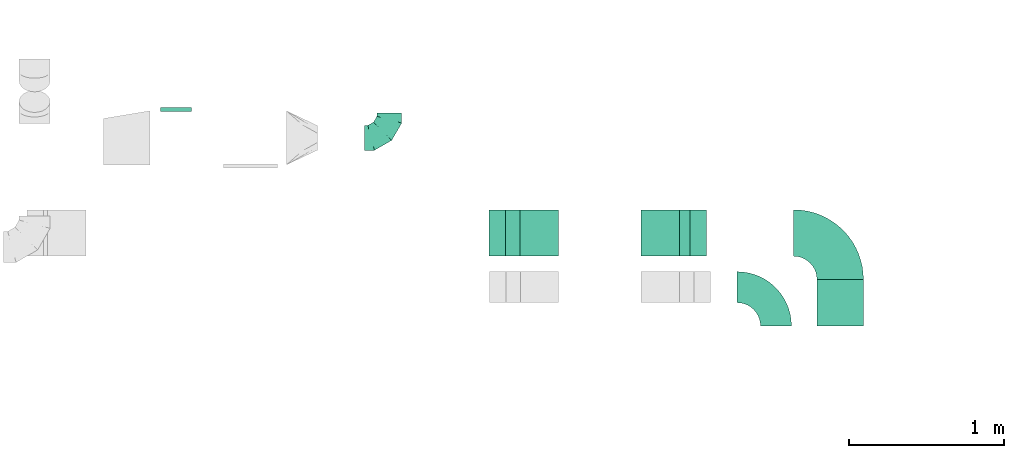
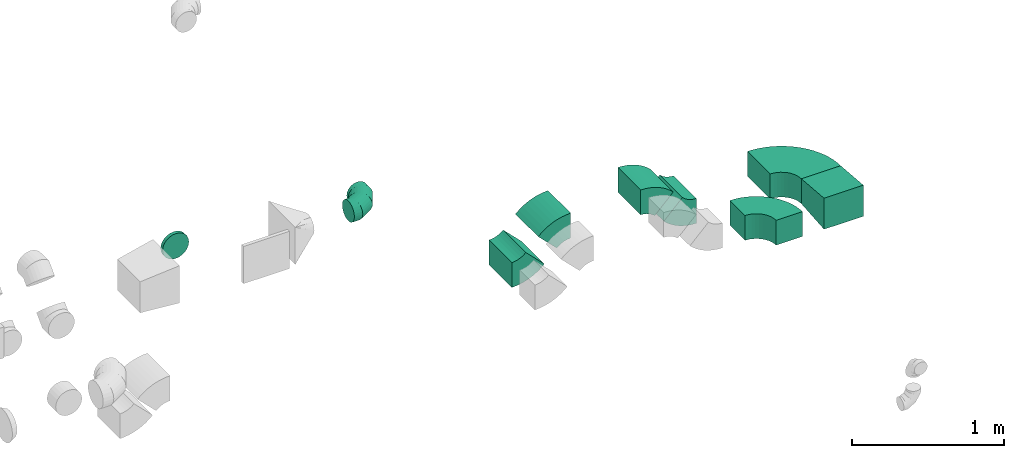
# One storey, part 31 of 44: 9 flow fittings.
"""IFC2X3 building model written with IfcOpenShell, lengths in millimetres."""

import ifcopenshell
import ifcopenshell.guid

model = None  # the IFC model being written
_history = None  # IfcOwnerHistory: only IFC2X3 demands one
_inside = {}  # id of a spatial element -> (the spatial element, [elements in it])
_under = {}  # id of a project, library or spatial element -> (it, [spatial elements below it])
_declared = {}  # id of a project -> (the project, [libraries it declares])
_typed = {}  # id of a type object -> (the type object, [elements of that type])
_made_of = {}  # id of a material, layer set ... -> (it, [elements and type objects made of it])


def new_model(schema):
    """Start an empty IFC model of exactly this schema.

    Asked for "IFC4X3", IfcOpenShell would pick the latest addendum, in which some entities
    have other attributes; the version numbers below select the first issue.
    IFC2X3 requires an IfcOwnerHistory on every rooted entity: one is made here for all.
    """
    global model, _history
    if schema == "IFC4X3":
        model = ifcopenshell.file(schema_version=(4, 3, 0, 0))
    else:
        model = ifcopenshell.file(schema=schema)
    _inside.clear()
    _under.clear()
    _declared.clear()
    _typed.clear()
    _made_of.clear()
    _history = None
    if model.schema == "IFC2X3":
        org = make("IfcOrganization", Name="unknown")
        user = make(
            "IfcPersonAndOrganization",
            ThePerson=make("IfcPerson", FamilyName="unknown"),
            TheOrganization=org,
        )
        app = make(
            "IfcApplication",
            ApplicationDeveloper=org,
            Version="unknown",
            ApplicationFullName="unknown",
            ApplicationIdentifier="unknown",
        )
        _history = make(
            "IfcOwnerHistory",
            OwningUser=user,
            OwningApplication=app,
            ChangeAction="ADDED",
            CreationDate=0,
        )
    return model


def make(cls, **values):
    """One entity of the class cls with the attributes given. An attribute that is None is left unset."""
    return model.create_entity(
        cls, **{name: value for name, value in values.items() if value is not None}
    )


def entity(cls, *values):
    """Any entity or typed value of the class cls, its attributes in the order of the schema. None: left unset."""
    e = model.create_entity(cls)
    for i, value in enumerate(values):
        if value is not None:
            e[i] = value
    return e


def rooted(cls, **values):
    """An entity with a GlobalId (a new one), such as an element, a storey or a relation."""
    return make(cls, GlobalId=ifcopenshell.guid.new(), OwnerHistory=_history, **values)


def si_unit(unit_type, name, prefix=None):
    """IfcSIUnit, for example si_unit("LENGTHUNIT", "METRE", prefix="MILLI")."""
    return make("IfcSIUnit", UnitType=unit_type, Prefix=prefix, Name=name)


def converted_unit(unit_type, name, factor, base, dimensions=None, offset=None):
    """IfcConversionBasedUnit, such as the inch: factor (a typed value) times the base unit."""
    return make(
        "IfcConversionBasedUnit"
        if offset is None
        else "IfcConversionBasedUnitWithOffset",
        ConversionOffset=offset,
        Dimensions=None
        if dimensions is None
        else entity("IfcDimensionalExponents", *dimensions),
        UnitType=unit_type,
        Name=name,
        ConversionFactor=make(
            "IfcMeasureWithUnit", ValueComponent=factor, UnitComponent=base
        ),
    )


def derived_unit(unit_type, elements):
    """IfcDerivedUnit: a product of units, each with its exponent."""
    return make(
        "IfcDerivedUnit",
        Elements=[
            make("IfcDerivedUnitElement", Unit=unit, Exponent=power)
            for unit, power in elements
        ],
        UnitType=unit_type,
    )


def assignment(units):
    """IfcUnitAssignment: the units of a project."""
    return None if units is None else make("IfcUnitAssignment", Units=units)


def point(xyz):
    """IfcCartesianPoint."""
    return None if xyz is None else make("IfcCartesianPoint", Coordinates=xyz)


def direction(xyz):
    """IfcDirection."""
    return None if xyz is None else make("IfcDirection", DirectionRatios=xyz)


def frame(location, z_axis=None, x_axis=None):
    """IfcAxis2Placement3D, a coordinate frame: its origin and axes. An axis left out is left unset."""
    return make(
        "IfcAxis2Placement3D",
        Location=point(location),
        Axis=direction(z_axis),
        RefDirection=direction(x_axis),
    )


def frame_2d(location, x_axis=None):
    """IfcAxis2Placement2D, a coordinate frame in the plane: its origin and x axis."""
    return make(
        "IfcAxis2Placement2D", Location=point(location), RefDirection=direction(x_axis)
    )


def origin():
    """The frame at (0, 0, 0) with its axes left unset."""
    return frame((0.0, 0.0, 0.0))


def place(relative_to, where):
    """IfcLocalPlacement: puts the frame where relative to a parent placement (None: the world)."""
    return make(
        "IfcLocalPlacement", PlacementRelTo=relative_to, RelativePlacement=where
    )


def context(
    kind, dimensions, precision=None, world=None, true_north=None, identifier=None
):
    """IfcGeometricRepresentationContext, for example the 3D "Model" context."""
    return make(
        "IfcGeometricRepresentationContext",
        ContextIdentifier=identifier,
        ContextType=kind,
        CoordinateSpaceDimension=dimensions,
        Precision=precision,
        WorldCoordinateSystem=world,
        TrueNorth=true_north,
    )


def subcontext(parent, identifier, kind, view, scale=None):
    """IfcGeometricRepresentationSubContext, for example "Body" below "Model"."""
    return make(
        "IfcGeometricRepresentationSubContext",
        ContextIdentifier=identifier,
        ContextType=kind,
        ParentContext=parent,
        TargetScale=scale,
        TargetView=view,
    )


def project(units=None, contexts=None):
    """IfcProject with its units and contexts."""
    return rooted(
        "IfcProject",
        Name="project",
        RepresentationContexts=contexts,
        UnitsInContext=assignment(units),
    )


def spatial(cls, under=None, at=None, **own):
    """A site, building, storey or space (cls), placed at a placement, below another one or the project."""
    s = rooted(cls, ObjectPlacement=at, **own)
    if under is not None:
        _under.setdefault(under.id(), (under, []))[1].append(s)
    return s


def polyline(points):
    """IfcPolyline through the points."""
    return make("IfcPolyline", Points=[point(p) for p in points])


def circle_curve(where, radius):
    """IfcCircle in the frame where."""
    return make("IfcCircle", Position=where, Radius=radius)


def parameter(value):
    """IfcParameterValue: where a trimmed curve begins or ends, as a parameter of its basis curve."""
    return model.create_entity("IfcParameterValue", value)


def trimmed(basis, trim1, trim2, sense, master):
    """IfcTrimmedCurve: the piece of a basis curve between two trims."""
    return make(
        "IfcTrimmedCurve",
        BasisCurve=basis,
        Trim1=trim1,
        Trim2=trim2,
        SenseAgreement=sense,
        MasterRepresentation=master,
    )


def segment(curve, same_sense, transition):
    """IfcCompositeCurveSegment."""
    return make(
        "IfcCompositeCurveSegment",
        Transition=transition,
        SameSense=same_sense,
        ParentCurve=curve,
    )


def composite_curve(segments, self_intersect=None):
    """IfcCompositeCurve: segments joined end to end."""
    return make("IfcCompositeCurve", Segments=segments, SelfIntersect=self_intersect)


def outline(outer, holes=None, kind="AREA"):
    """IfcArbitraryClosedProfileDef: a profile drawn as a closed curve; with holes, ...WithVoids."""
    if holes is None:
        return make("IfcArbitraryClosedProfileDef", ProfileType=kind, OuterCurve=outer)
    return make(
        "IfcArbitraryProfileDefWithVoids",
        ProfileType=kind,
        OuterCurve=outer,
        InnerCurves=holes,
    )


def extrude(swept, where, along, depth):
    """IfcExtrudedAreaSolid: the profile swept, set in the frame where, extruded along a direction by depth."""
    return make(
        "IfcExtrudedAreaSolid",
        SweptArea=swept,
        Position=where,
        ExtrudedDirection=direction(along),
        Depth=depth,
    )


def faces_of(points, faces, orient=None, outer=None):
    """IfcFace entities. A face is a list of loops; a loop is a list of indices into points, from 0.

    orient and outer hold one flag for each loop. By default every Orientation is true, the
    first loop of a face is its IfcFaceOuterBound and the others are IfcFaceBound.
    """
    made = []
    for i, loops in enumerate(faces):
        bounds = []
        for j, loop in enumerate(loops):
            is_outer = j == 0 if outer is None else outer[i][j]
            bounds.append(
                make(
                    "IfcFaceOuterBound" if is_outer else "IfcFaceBound",
                    Bound=make("IfcPolyLoop", Polygon=[points[k] for k in loop]),
                    Orientation=True if orient is None else orient[i][j],
                )
            )
        made.append(make("IfcFace", Bounds=bounds))
    return made


def faceted_brep(points, faces, orient=None, outer=None, voids=None):
    """IfcFacetedBrep: a solid bounded by flat faces; with voids (closed shells), ...WithVoids."""
    shared = [point(p) for p in points]
    hull = make("IfcClosedShell", CfsFaces=faces_of(shared, faces, orient, outer))
    if voids is None:
        return make("IfcFacetedBrep", Outer=hull)
    return make(
        "IfcFacetedBrepWithVoids",
        Outer=hull,
        Voids=[
            make(cls, CfsFaces=faces_of(shared, fs, o, b)) for cls, fs, o, b in voids
        ],
    )


def shape(context_of_items, identifier, shape_type, items):
    """IfcShapeRepresentation: the items that make up one representation, for example the "Body"."""
    return make(
        "IfcShapeRepresentation",
        ContextOfItems=context_of_items,
        RepresentationIdentifier=identifier,
        RepresentationType=shape_type,
        Items=items,
    )


def source(mapping_origin, context_of_items, identifier, shape_type, items):
    """IfcRepresentationMap: a shape defined once, which mapped items show again and again."""
    return make(
        "IfcRepresentationMap",
        MappingOrigin=mapping_origin,
        MappedRepresentation=shape(context_of_items, identifier, shape_type, items),
    )


def transform(
    local_origin,
    x_axis=None,
    y_axis=None,
    z_axis=None,
    scale=None,
    scale2=None,
    scale3=None,
    uniform=True,
):
    """IfcCartesianTransformationOperator3D, or its non-uniform kind. x_axis, y_axis, z_axis: its Axis1, 2, 3."""
    if uniform:
        return make(
            "IfcCartesianTransformationOperator3D",
            Axis1=direction(x_axis),
            Axis2=direction(y_axis),
            LocalOrigin=point(local_origin),
            Scale=scale,
            Axis3=direction(z_axis),
        )
    return make(
        "IfcCartesianTransformationOperator3DnonUniform",
        Axis1=direction(x_axis),
        Axis2=direction(y_axis),
        LocalOrigin=point(local_origin),
        Scale=scale,
        Axis3=direction(z_axis),
        Scale2=scale2,
        Scale3=scale3,
    )


def mapped(mapping_source, mapping_target):
    """IfcMappedItem: shows the shape of a source again, moved by a transform."""
    return make(
        "IfcMappedItem", MappingSource=mapping_source, MappingTarget=mapping_target
    )


def material(Name=None, Category=None):
    """IfcMaterial."""
    return make("IfcMaterial", Name=Name, Category=Category)


def made_of(thing, what):
    """Note that an element or type object is made of a material, layer set ...; save() writes the relation."""
    if what is not None:
        _made_of.setdefault(what.id(), (what, []))[1].append(thing)
    return thing


def type_object(cls, material=None, **own):
    """A type object (cls), such as IfcWallType, which elements share."""
    return made_of(rooted(cls, **own), material)


def type_shapes(of_type, sources):
    """Give a type object the sources (RepresentationMaps) that its elements show as mapped items."""
    of_type.RepresentationMaps = sources


def element(
    cls,
    number,
    at=None,
    inside=None,
    cuts=None,
    type_object=None,
    material=None,
    context=None,
    identifier="Body",
    shape_type=None,
    held_by="IfcProductDefinitionShape",
    body=None,
    shapes=None,
    **own,
):
    """One element of the class cls, such as IfcWall. Its Tag is "e" and its number.

    at: its placement. inside: the storey or other place that contains it. cuts: it is an
    opening in that element (IfcRelVoidsElement). A single representation is given by context,
    identifier, shape_type and body (its items); several are given by shapes. held_by: the class
    of the entity that holds the representations. save() writes the other relations.
    """
    e = rooted(cls, Tag="e%d" % number, ObjectPlacement=at, **own)
    if body is not None:
        shapes = [shape(context, identifier, shape_type, body)]
    if shapes is not None:
        e.Representation = make(held_by, Representations=shapes)
    if inside is not None:
        _inside.setdefault(inside.id(), (inside, []))[1].append(e)
    if cuts is not None:
        rooted(
            "IfcRelVoidsElement", RelatingBuildingElement=cuts, RelatedOpeningElement=e
        )
    if type_object is not None:
        _typed.setdefault(type_object.id(), (type_object, []))[1].append(e)
    return made_of(e, material)


def aggregate(whole, parts):
    """IfcRelAggregates: a whole, such as a stair, and the parts it consists of."""
    return rooted("IfcRelAggregates", RelatingObject=whole, RelatedObjects=parts)


def save(model, path):
    """Write the relations noted so far, then the file.

    IfcRelAggregates (storeys below a building ...), IfcRelContainedInSpatialStructure (elements
    in a storey), IfcRelDefinesByType, IfcRelAssociatesMaterial and IfcRelDeclares: one each for
    every whole, place, type object, material and project.
    """
    for whole, parts in _under.values():
        aggregate(whole, parts)
    for where, things in _inside.values():
        rooted(
            "IfcRelContainedInSpatialStructure",
            RelatedElements=things,
            RelatingStructure=where,
        )
    for kind, things in _typed.values():
        rooted("IfcRelDefinesByType", RelatedObjects=things, RelatingType=kind)
    for what, things in _made_of.values():
        rooted("IfcRelAssociatesMaterial", RelatedObjects=things, RelatingMaterial=what)
    for by, libraries in _declared.values():
        rooted("IfcRelDeclares", RelatingContext=by, RelatedDefinitions=libraries)
    model.write(path)


model = new_model("IFC2X3")

# Units and contexts
model_context = context("Model", 3, precision=0.01, world=origin(), true_north=direction((6.12303176911189e-17, 1.0)))
body_context = subcontext(model_context, "Body", "Model", "MODEL_VIEW")
ifc_project = project(units=[si_unit("LENGTHUNIT", "METRE", prefix="MILLI"), si_unit("AREAUNIT", "SQUARE_METRE"), si_unit("VOLUMEUNIT", "CUBIC_METRE"), converted_unit("PLANEANGLEUNIT", "DEGREE", entity("IfcRatioMeasure", 0.0174532925199433), si_unit("PLANEANGLEUNIT", "RADIAN"), dimensions=[0, 0, 0, 0, 0, 0, 0]), si_unit("MASSUNIT", "GRAM", prefix="KILO"), derived_unit("MASSDENSITYUNIT", [(si_unit("MASSUNIT", "GRAM", prefix="KILO"), 1), (si_unit("LENGTHUNIT", "METRE"), -3)]), derived_unit("MOMENTOFINERTIAUNIT", [(si_unit("LENGTHUNIT", "METRE"), 4)]), si_unit("TIMEUNIT", "SECOND"), si_unit("FREQUENCYUNIT", "HERTZ"), si_unit("THERMODYNAMICTEMPERATUREUNIT", "DEGREE_CELSIUS"), derived_unit("THERMALTRANSMITTANCEUNIT", [(si_unit("MASSUNIT", "GRAM", prefix="KILO"), 1), (si_unit("THERMODYNAMICTEMPERATUREUNIT", "KELVIN"), -1), (si_unit("TIMEUNIT", "SECOND"), -3)]), derived_unit("VOLUMETRICFLOWRATEUNIT", [(si_unit("LENGTHUNIT", "METRE"), 3), (si_unit("TIMEUNIT", "SECOND"), -1)]), derived_unit("MASSFLOWRATEUNIT", [(si_unit("MASSUNIT", "GRAM", prefix="KILO"), 1), (si_unit("TIMEUNIT", "SECOND"), -1)]), derived_unit("ROTATIONALFREQUENCYUNIT", [(si_unit("TIMEUNIT", "SECOND"), -1)]), si_unit("ELECTRICCURRENTUNIT", "AMPERE"), si_unit("ELECTRICVOLTAGEUNIT", "VOLT"), si_unit("POWERUNIT", "WATT"), si_unit("FORCEUNIT", "NEWTON", prefix="KILO"), si_unit("ILLUMINANCEUNIT", "LUX"), si_unit("LUMINOUSFLUXUNIT", "LUMEN"), si_unit("LUMINOUSINTENSITYUNIT", "CANDELA"), derived_unit("USERDEFINED", [(si_unit("MASSUNIT", "GRAM", prefix="KILO"), -1), (si_unit("LENGTHUNIT", "METRE"), -2), (si_unit("TIMEUNIT", "SECOND"), 3), (si_unit("LUMINOUSFLUXUNIT", "LUMEN"), 1)]), derived_unit("LINEARVELOCITYUNIT", [(si_unit("LENGTHUNIT", "METRE"), 1), (si_unit("TIMEUNIT", "SECOND"), -1)]), si_unit("PRESSUREUNIT", "PASCAL"), derived_unit("USERDEFINED", [(si_unit("LENGTHUNIT", "METRE"), -2), (si_unit("MASSUNIT", "GRAM", prefix="KILO"), 1), (si_unit("TIMEUNIT", "SECOND"), -2)]), derived_unit("LINEARFORCEUNIT", [(si_unit("MASSUNIT", "GRAM", prefix="KILO"), 1), (si_unit("LENGTHUNIT", "METRE"), 1), (si_unit("TIMEUNIT", "SECOND"), -2), (si_unit("LENGTHUNIT", "METRE"), -1)]), derived_unit("PLANARFORCEUNIT", [(si_unit("MASSUNIT", "GRAM", prefix="KILO"), 1), (si_unit("LENGTHUNIT", "METRE"), 1), (si_unit("TIMEUNIT", "SECOND"), -2), (si_unit("LENGTHUNIT", "METRE"), -2)])], contexts=[model_context])

# Site, building, storey
site_placement = place(None, origin())
site = spatial("IfcSite", under=ifc_project, at=site_placement, CompositionType="ELEMENT")
building_placement = place(site_placement, origin())
building = spatial("IfcBuilding", under=site, at=building_placement, CompositionType="ELEMENT")
storey_placement = place(building_placement, frame((0.0, 0.0, 15900.0)))
storey = spatial("IfcBuildingStorey", under=building, at=storey_placement, CompositionType="ELEMENT", Elevation=15900.0)

# Flow fittings
ifc_material = material()
duct_fitting_type_1 = type_object("IfcDuctFittingType", PredefinedType="NOTDEFINED", material=ifc_material)
shared_shape_1 = source(origin(), body_context, "Body", "SweptSolid", [
    extrude(outline(polyline([(-159.86, -112.11), (141.18, -112.11), (157.79, 87.2), (-139.1, 137.03), (-159.86, -112.11)])), frame((150.0, -150.0, 0.0), z_axis=(0.0, 1.0, 0.0), x_axis=(0.996545758244872, 0.0, -0.0830454798538357)), (0.0, 0.0, 1.0), 300.0),
])
type_shapes(duct_fitting_type_1, [shared_shape_1])
flow_fitting_1_placement = place(storey_placement, frame((62044.65, 13925.32, 2975.0), z_axis=(0.0, 0.0, 1.0), x_axis=(0.0, 1.0, 0.0)))
element("IfcFlowFitting", 1, at=flow_fitting_1_placement, inside=storey, type_object=duct_fitting_type_1, material=ifc_material, context=body_context, shape_type="MappedRepresentation", body=[
    mapped(shared_shape_1, transform((0.0, 0.0, 0.0), scale=1.0)),
])
duct_fitting_type_2 = type_object("IfcDuctFittingType", PredefinedType="NOTDEFINED", material=ifc_material)
shared_shape_2 = source(origin(), body_context, "Body", "Brep", [
    faceted_brep([(-160.0, 0.0, -80.0), (-160.0, -20.71, -77.27), (-160.0, -40.0, -69.28), (-160.0, -56.57, -56.57), (-160.0, -69.28, -40.0), (-160.0, -77.27, -20.71), (-160.0, -80.0, 0.0), (-160.0, -77.27, 20.71), (-160.0, -69.28, 40.0), (-160.0, -56.57, 56.57), (-160.0, -40.0, 69.28), (-160.0, -20.71, 77.27), (-160.0, 0.0, 80.0), (-160.0, 20.71, 77.27), (-160.0, 40.0, 69.28), (-160.0, 56.57, 56.57), (-160.0, 69.28, 40.0), (-160.0, 77.27, 20.71), (-160.0, 80.0, 0.0), (-160.0, 77.27, -20.71), (-160.0, 69.28, -40.0), (-160.0, 56.57, -56.57), (-160.0, 40.0, -69.28), (-160.0, 20.71, -77.27), (-122.68, 20.71, 77.27), (-127.85, 40.0, 69.28), (-117.13, 0.0, 80.0), (-132.29, 56.57, 56.57), (-137.83, 77.27, 20.71), (-138.56, 80.0, 0.0), (-135.69, 69.28, 40.0), (-135.69, 69.28, -40.0), (-132.29, 56.57, -56.57), (-137.83, 77.27, -20.71), (-122.68, 20.71, -77.27), (-117.13, 0.0, -80.0), (-127.85, 40.0, -69.28), (-111.58, -20.71, -77.27), (-106.41, -40.0, -69.28), (-101.97, -56.57, -56.57), (-98.56, -69.28, -40.0), (-96.42, -77.27, -20.71), (-95.69, -80.0, 0.0), (-96.42, -77.27, 20.71), (-98.56, -69.28, 40.0), (-101.97, -56.57, 56.57), (-106.41, -40.0, 69.28), (-111.58, -20.71, 77.27), (-58.03, 58.03, 77.27), (-72.15, 72.15, 69.28), (-42.87, 42.87, 80.0), (-84.28, 84.28, 56.57), (-93.59, 93.59, 40.0), (-99.44, 99.44, 20.71), (-101.44, 101.44, 0.0), (-99.44, 99.44, -20.71), (-93.59, 93.59, -40.0), (-84.28, 84.28, -56.57), (-58.03, 58.03, -77.27), (-42.87, 42.87, -80.0), (-72.15, 72.15, -69.28), (-27.71, 27.71, -77.27), (-13.59, 13.59, -69.28), (-1.46, 1.46, -56.57), (7.85, -7.85, -40.0), (13.7, -13.7, -20.71), (15.69, -15.69, 0.0), (13.7, -13.7, 20.71), (7.85, -7.85, 40.0), (-1.46, 1.46, 56.57), (-13.59, 13.59, 69.28), (-27.71, 27.71, 77.27), (-20.71, 122.68, 77.27), (-40.0, 127.85, 69.28), (0.0, 117.13, 80.0), (-56.57, 132.29, 56.57), (-69.28, 135.69, 40.0), (-77.27, 137.83, 20.71), (-80.0, 138.56, 0.0), (-77.27, 137.83, -20.71), (-69.28, 135.69, -40.0), (-56.57, 132.29, -56.57), (-20.71, 122.68, -77.27), (0.0, 117.13, -80.0), (-40.0, 127.85, -69.28), (20.71, 111.58, -77.27), (40.0, 106.41, -69.28), (56.57, 101.97, -56.57), (69.28, 98.56, -40.0), (77.27, 96.42, -20.71), (80.0, 95.69, 0.0), (77.27, 96.42, 20.71), (69.28, 98.56, 40.0), (56.57, 101.97, 56.57), (40.0, 106.41, 69.28), (20.71, 111.58, 77.27), (-20.71, 160.0, -77.27), (-40.0, 160.0, -69.28), (-56.57, 160.0, -56.57), (-69.28, 160.0, -40.0), (-77.27, 160.0, -20.71), (-80.0, 160.0, 0.0), (-77.27, 160.0, 20.71), (-69.28, 160.0, 40.0), (-56.57, 160.0, 56.57), (-40.0, 160.0, 69.28), (-20.71, 160.0, 77.27), (0.0, 160.0, 80.0), (20.71, 160.0, 77.27), (40.0, 160.0, 69.28), (56.57, 160.0, 56.57), (69.28, 160.0, 40.0), (77.27, 160.0, 20.71), (80.0, 160.0, 0.0), (77.27, 160.0, -20.71), (69.28, 160.0, -40.0), (56.57, 160.0, -56.57), (40.0, 160.0, -69.28), (20.71, 160.0, -77.27), (0.0, 160.0, -80.0)], [[[0, 1, 2, 3, 4, 5, 6, 7, 8, 9, 10, 11, 12, 13, 14, 15, 16, 17, 18, 19, 20, 21, 22, 23]], [[24, 25, 14, 13]], [[26, 24, 13, 12]], [[14, 25, 27, 15]], [[28, 29, 18, 17]], [[30, 28, 17, 16]], [[15, 27, 30, 16]], [[20, 31, 32, 21]], [[33, 31, 20, 19]], [[18, 29, 33, 19]], [[34, 35, 0, 23]], [[36, 34, 23, 22]], [[32, 36, 22, 21]], [[1, 0, 35, 37]], [[2, 1, 37, 38]], [[3, 2, 38, 39]], [[5, 4, 40, 41]], [[6, 5, 41, 42]], [[39, 40, 4, 3]], [[6, 42, 43, 7]], [[7, 43, 44, 8]], [[8, 44, 45, 9]], [[9, 45, 46, 10]], [[10, 46, 47, 11]], [[26, 12, 11, 47]], [[48, 49, 25, 24]], [[50, 48, 24, 26]], [[27, 25, 49, 51]], [[52, 53, 28, 30]], [[51, 52, 30, 27]], [[29, 28, 53, 54]], [[55, 56, 31, 33]], [[54, 55, 33, 29]], [[32, 31, 56, 57]], [[58, 59, 35, 34]], [[60, 58, 34, 36]], [[57, 60, 36, 32]], [[37, 35, 59, 61]], [[38, 37, 61, 62]], [[39, 38, 62, 63]], [[41, 40, 64, 65]], [[42, 41, 65, 66]], [[63, 64, 40, 39]], [[43, 42, 66, 67]], [[44, 43, 67, 68]], [[68, 69, 45, 44]], [[46, 45, 69, 70]], [[47, 46, 70, 71]], [[26, 47, 71, 50]], [[72, 73, 49, 48]], [[74, 72, 48, 50]], [[51, 49, 73, 75]], [[76, 77, 53, 52]], [[75, 76, 52, 51]], [[54, 53, 77, 78]], [[79, 80, 56, 55]], [[78, 79, 55, 54]], [[57, 56, 80, 81]], [[82, 83, 59, 58]], [[84, 82, 58, 60]], [[81, 84, 60, 57]], [[61, 59, 83, 85]], [[62, 61, 85, 86]], [[63, 62, 86, 87]], [[65, 64, 88, 89]], [[66, 65, 89, 90]], [[87, 88, 64, 63]], [[67, 66, 90, 91]], [[68, 67, 91, 92]], [[92, 93, 69, 68]], [[70, 69, 93, 94]], [[71, 70, 94, 95]], [[50, 71, 95, 74]], [[96, 97, 98, 99, 100, 101, 102, 103, 104, 105, 106, 107, 108, 109, 110, 111, 112, 113, 114, 115, 116, 117, 118, 119]], [[72, 74, 107, 106]], [[73, 72, 106, 105]], [[75, 73, 105, 104]], [[77, 76, 103, 102]], [[78, 77, 102, 101]], [[75, 104, 103, 76]], [[78, 101, 100, 79]], [[79, 100, 99, 80]], [[80, 99, 98, 81]], [[84, 97, 96, 82]], [[82, 96, 119, 83]], [[84, 81, 98, 97]], [[118, 117, 86, 85]], [[119, 118, 85, 83]], [[116, 87, 86, 117]], [[88, 115, 114, 89]], [[89, 114, 113, 90]], [[115, 88, 87, 116]], [[112, 111, 92, 91]], [[113, 112, 91, 90]], [[111, 110, 93, 92]], [[95, 94, 109, 108]], [[74, 95, 108, 107]], [[110, 109, 94, 93]]]),
])
type_shapes(duct_fitting_type_2, [shared_shape_2])
flow_fitting_2_placement = place(storey_placement, frame((59134.6, 15139.34, 3284.56), z_axis=(6.73421288581176e-05, 0.0, 0.999999997732519), x_axis=(0.999999997732519, 0.0, -6.73421288581176e-05)))
element("IfcFlowFitting", 2, at=flow_fitting_2_placement, inside=storey, type_object=duct_fitting_type_2, material=ifc_material, context=body_context, shape_type="MappedRepresentation", body=[
    mapped(shared_shape_2, transform((0.0, 0.0, 0.0), scale=1.0)),
])
duct_fitting_type_3 = type_object("IfcDuctFittingType", PredefinedType="NOTDEFINED", material=ifc_material)
shared_shape_3 = source(origin(), body_context, "Body", "Brep", [
    faceted_brep([(20.0, 0.0, -100.0), (20.0, 25.88, -96.59), (20.0, 50.0, -86.6), (20.0, 70.71, -70.71), (20.0, 86.6, -50.0), (20.0, 96.59, -25.88), (20.0, 100.0, 0.0), (20.0, 96.59, 25.88), (20.0, 86.6, 50.0), (20.0, 70.71, 70.71), (20.0, 50.0, 86.6), (20.0, 25.88, 96.59), (20.0, 0.0, 100.0), (20.0, -25.88, 96.59), (20.0, -50.0, 86.6), (20.0, -70.71, 70.71), (20.0, -86.6, 50.0), (20.0, -96.59, 25.88), (20.0, -100.0, 0.0), (20.0, -96.59, -25.88), (20.0, -86.6, -50.0), (20.0, -70.71, -70.71), (20.0, -50.0, -86.6), (20.0, -25.88, -96.59), (0.0, 0.0, 100.0), (-6.1, 0.0, 100.0), (-6.1, -25.88, 96.59), (0.0, -25.88, 96.59), (-6.1, -50.0, 86.6), (0.0, -50.0, 86.6), (0.0, -70.71, 70.71), (-6.1, -70.71, 70.71), (0.0, -86.6, 50.0), (-6.1, -86.6, 50.0), (-6.1, -96.59, 25.88), (0.0, -96.59, 25.88), (-6.1, -100.0, 0.0), (0.0, -100.0, 0.0), (-6.1, -96.59, -25.88), (0.0, -96.59, -25.88), (-6.1, -86.6, -50.0), (0.0, -86.6, -50.0), (0.0, -70.71, -70.71), (-6.1, -70.71, -70.71), (0.0, -50.0, -86.6), (-6.1, -50.0, -86.6), (-6.1, -25.88, -96.59), (0.0, -25.88, -96.59), (-6.1, 0.0, -100.0), (0.0, 0.0, -100.0), (-6.1, 25.88, -96.59), (0.0, 25.88, -96.59), (-6.1, 50.0, -86.6), (0.0, 50.0, -86.6), (0.0, 70.71, -70.71), (-6.1, 70.71, -70.71), (0.0, 86.6, -50.0), (-6.1, 86.6, -50.0), (-6.1, 96.59, -25.88), (0.0, 96.59, -25.88), (-6.1, 100.0, 0.0), (0.0, 100.0, 0.0), (-6.1, 96.59, 25.88), (0.0, 96.59, 25.88), (-6.1, 86.6, 50.0), (0.0, 86.6, 50.0), (0.0, 70.71, 70.71), (-6.1, 70.71, 70.71), (0.0, 50.0, 86.6), (-6.1, 50.0, 86.6), (-6.1, 25.88, 96.59), (0.0, 25.88, 96.59)], [[[0, 1, 2, 3, 4, 5, 6, 7, 8, 9, 10, 11, 12, 13, 14, 15, 16, 17, 18, 19, 20, 21, 22, 23]], [[13, 12, 24, 25, 26, 27]], [[14, 13, 27, 26, 28, 29]], [[30, 15, 14, 29, 28, 31]], [[17, 16, 32, 33, 34, 35]], [[18, 17, 35, 34, 36, 37]], [[32, 16, 15, 30, 31, 33]], [[19, 18, 37, 36, 38, 39]], [[20, 19, 39, 38, 40, 41]], [[42, 21, 20, 41, 40, 43]], [[23, 22, 44, 45, 46, 47]], [[0, 23, 47, 46, 48, 49]], [[44, 22, 21, 42, 43, 45]], [[1, 0, 49, 48, 50, 51]], [[2, 1, 51, 50, 52, 53]], [[54, 3, 2, 53, 52, 55]], [[5, 4, 56, 57, 58, 59]], [[6, 5, 59, 58, 60, 61]], [[56, 4, 3, 54, 55, 57]], [[7, 6, 61, 60, 62, 63]], [[8, 7, 63, 62, 64, 65]], [[66, 9, 8, 65, 64, 67]], [[11, 10, 68, 69, 70, 71]], [[12, 11, 71, 70, 25, 24]], [[68, 10, 9, 66, 67, 69]], [[46, 45, 43, 40, 38, 36, 34, 33, 31, 28, 26, 25, 70, 69, 67, 64, 62, 60, 58, 57, 55, 52, 50, 48]]]),
])
type_shapes(duct_fitting_type_3, [shared_shape_3])
flow_fitting_3_placement = place(storey_placement, frame((57758.15, 15314.34, 3325.0), z_axis=(0.0, 0.0, -1.0), x_axis=(0.0, 1.0, 0.0)))
element("IfcFlowFitting", 3, at=flow_fitting_3_placement, inside=storey, type_object=duct_fitting_type_3, material=ifc_material, context=body_context, shape_type="MappedRepresentation", body=[
    mapped(shared_shape_3, transform((0.0, 0.0, 0.0), scale=1.0)),
])
duct_fitting_type_4 = type_object("IfcDuctFittingType", PredefinedType="NOTDEFINED", material=ifc_material)
shared_shape_4 = source(origin(), body_context, "Body", "SweptSolid", [
    extrude(outline(composite_curve([segment(polyline([(-300.0, -150.0), (0.0, -150.0)]), True, "CONTINUOUS"), segment(trimmed(circle_curve(frame_2d((150.0, -150.0), x_axis=(0.0, 1.0)), 150.0), [parameter(0.0)], [parameter(90.0)], True, "PARAMETER"), False, "CONTINUOUS"), segment(polyline([(150.0, 0.0), (150.0, 300.0)]), True, "CONTINUOUS"), segment(trimmed(circle_curve(frame_2d((150.0, -150.0), x_axis=(0.0, 1.0)), 450.0), [parameter(0.0)], [parameter(90.0000000000001)], True, "PARAMETER"), True, "CONTINUOUS")], self_intersect=False)), frame((-150.0, 150.0, -100.0), z_axis=(0.0, 0.0, 1.0), x_axis=(-1.0, 0.0, 0.0)), (0.0, 0.0, 1.0), 200.0),
])
type_shapes(duct_fitting_type_4, [shared_shape_4])
flow_fitting_4_placement = place(storey_placement, frame((62044.65, 14525.32, 2975.0), z_axis=(0.0, 0.0, 1.0), x_axis=(0.0, 1.0, 0.0)))
element("IfcFlowFitting", 4, at=flow_fitting_4_placement, inside=storey, type_object=duct_fitting_type_4, material=ifc_material, context=body_context, shape_type="MappedRepresentation", body=[
    mapped(shared_shape_4, transform((0.0, 0.0, 0.0), scale=1.0)),
])
duct_fitting_type_5 = type_object("IfcDuctFittingType", PredefinedType="NOTDEFINED", material=ifc_material)
shared_shape_5 = source(origin(), body_context, "Body", "SweptSolid", [
    extrude(outline(composite_curve([segment(polyline([(-136.61, -88.39), (63.39, -88.39)]), True, "CONTINUOUS"), segment(trimmed(circle_curve(frame_2d((213.39, -88.39), x_axis=(-0.707106781186546, 0.707106781186546)), 150.0), [parameter(0.0)], [parameter(45.0)], True, "PARAMETER"), False, "CONTINUOUS"), segment(polyline([(107.32, 17.68), (-34.1, 159.1)]), True, "CONTINUOUS"), segment(trimmed(circle_curve(frame_2d((213.39, -88.39), x_axis=(-0.707106781186546, 0.707106781186546)), 350.0), [parameter(0.0)], [parameter(45.0)], True, "PARAMETER"), True, "CONTINUOUS")], self_intersect=False)), frame((-15.17, 36.61, -150.0), z_axis=(0.0, 0.0, 1.0), x_axis=(-0.707106781186547, 0.707106781186548, 0.0)), (0.0, 0.0, 1.0), 300.0),
])
type_shapes(duct_fitting_type_5, [shared_shape_5])
for number, where, z_axis, x_axis in (
    (5, (60123.03, 14525.32, 3191.05), (0.0, 1.0, 0.0), (0.707106781186534, 0.0, 0.707106781186561)),
    (6, (60863.03, 14525.32, 3191.05), (0.0, 1.0, 0.0), (1.0, 0.0, 0.0)),
    (7, (61079.09, 14525.32, 2975.0), (0.0, -1.0, 0.0), (0.707106781186503, 0.0, -0.707106781186593)),
    (8, (59881.98, 14525.32, 2950.0), (0.0, 1.0, 0.0), (-0.707106781186637, 0.0, -0.707106781186459)),
):
    element("IfcFlowFitting", number, at=place(storey_placement, frame(where, z_axis=z_axis, x_axis=x_axis)), inside=storey, type_object=duct_fitting_type_5, material=ifc_material, context=body_context, shape_type="MappedRepresentation", body=[
        mapped(shared_shape_5, transform((0.0, 0.0, 0.0), scale=1.0)),
    ])
duct_fitting_type_6 = type_object("IfcDuctFittingType", PredefinedType="NOTDEFINED", material=ifc_material)
shared_shape_6 = source(origin(), body_context, "Body", "SweptSolid", [
    extrude(outline(composite_curve([segment(polyline([(-225.0, -125.0), (-25.0, -125.0)]), True, "CONTINUOUS"), segment(trimmed(circle_curve(frame_2d((125.0, -125.0), x_axis=(0.0, 1.0)), 150.0), [parameter(0.0)], [parameter(90.0)], True, "PARAMETER"), False, "CONTINUOUS"), segment(polyline([(125.0, 25.0), (125.0, 225.0)]), True, "CONTINUOUS"), segment(trimmed(circle_curve(frame_2d((125.0, -125.0), x_axis=(0.0, 1.0)), 350.0), [parameter(0.0)], [parameter(90.0)], True, "PARAMETER"), True, "CONTINUOUS")], self_intersect=False)), frame((-125.0, 125.0, -100.0), z_axis=(0.0, 0.0, 1.0), x_axis=(-1.0, 0.0, 0.0)), (0.0, 0.0, 1.0), 200.0),
])
type_shapes(duct_fitting_type_6, [shared_shape_6])
flow_fitting_5_placement = place(storey_placement, frame((61630.06, 14175.53, 2950.0), z_axis=(0.0, 0.0, 1.0), x_axis=(0.0, 1.0, 0.0)))
element("IfcFlowFitting", 9, at=flow_fitting_5_placement, inside=storey, type_object=duct_fitting_type_6, material=ifc_material, context=body_context, shape_type="MappedRepresentation", body=[
    mapped(shared_shape_6, transform((0.0, 0.0, 0.0), scale=1.0)),
])

save(model, "model.ifc")
